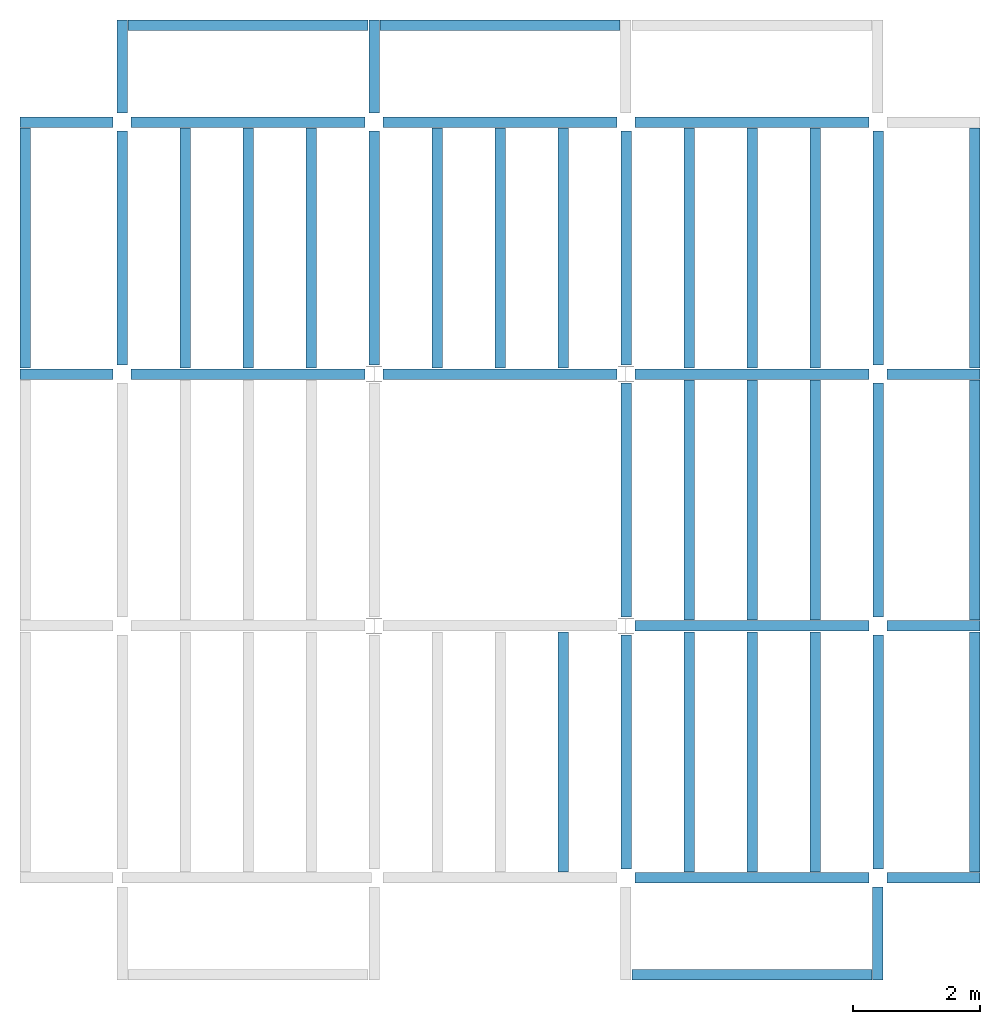
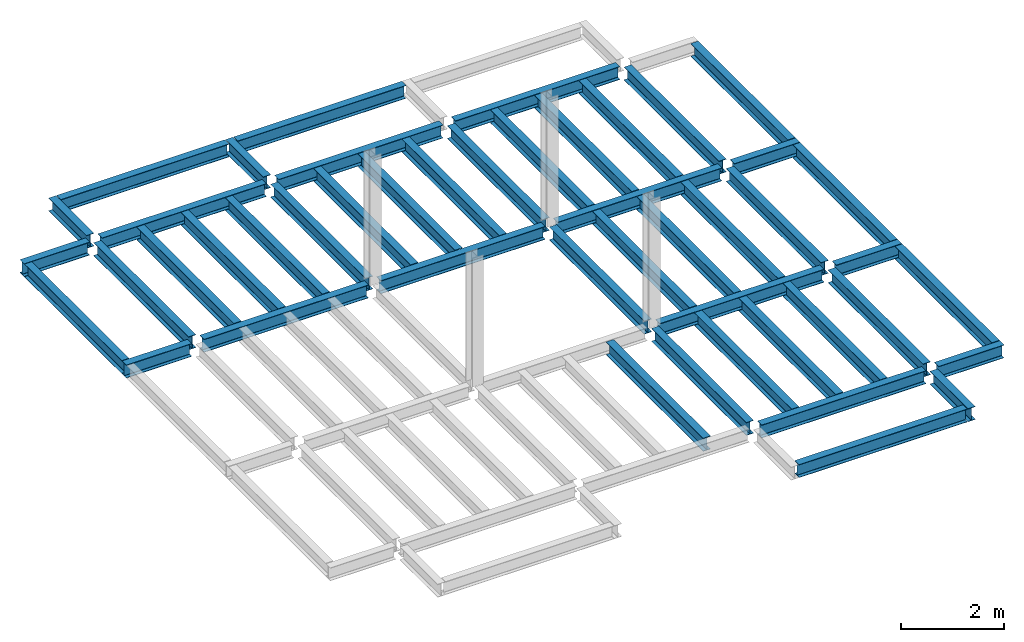
# One storey, part 2 of 3: 47 beams, 6 elements without a shape of their own.
"""IFC4 building model written with IfcOpenShell, lengths in feet."""

from ifc_helpers import new_model, entity, si_unit, converted_unit, derived_unit, direction, frame, origin, place, context, subcontext, project, spatial, line, arc, indexed_curve, outline, extrude, source, transform, mapped, material, type_object, type_shapes, element, aggregate, save


model = new_model("IFC4")

# Units and contexts
model_context = context("Model", 3, precision=0.0001, world=origin(), true_north=direction((6.123233995736766e-17, 1.0)))
plan_context = context("Plan", 3, precision=0.0001, world=origin(), true_north=direction((6.123233995736766e-17, 1.0)))
body_context = subcontext(model_context, "Body", "Model", "MODEL_VIEW")
ifc_project = project(units=[converted_unit("LENGTHUNIT", "FOOT", entity("IfcLengthMeasure", 0.3048), si_unit("LENGTHUNIT", "METRE"), dimensions=[1, 0, 0, 0, 0, 0, 0]), converted_unit("AREAUNIT", "SQUARE FOOT", entity("IfcAreaMeasure", 0.09290304), si_unit("AREAUNIT", "SQUARE_METRE"), dimensions=[2, 0, 0, 0, 0, 0, 0]), converted_unit("PLANEANGLEUNIT", "DEGREE", entity("IfcPlaneAngleMeasure", 0.017453292519943278), si_unit("PLANEANGLEUNIT", "RADIAN"), dimensions=[0, 0, 0, 0, 0, 0, 0]), converted_unit("VOLUMEUNIT", "CUBIC FOOT", entity("IfcVolumeMeasure", 0.028316846592000004), si_unit("VOLUMEUNIT", "CUBIC_METRE"), dimensions=[3, 0, 0, 0, 0, 0, 0]), si_unit("PRESSUREUNIT", "PASCAL"), derived_unit("MASSDENSITYUNIT", [(si_unit("MASSUNIT", "GRAM", prefix="KILO"), 1), (si_unit("LENGTHUNIT", "METRE"), -3)]), derived_unit("VAPORPERMEABILITYUNIT", [(si_unit("LENGTHUNIT", "METRE"), -1), (si_unit("TIMEUNIT", "SECOND"), 1)]), derived_unit("USERDEFINED", [(si_unit("MASSUNIT", "GRAM", prefix="KILO"), 1), (si_unit("LENGTHUNIT", "METRE"), 3), (si_unit("TIMEUNIT", "SECOND"), -3), (si_unit("ELECTRICCURRENTUNIT", "AMPERE"), -2)]), derived_unit("MODULUSOFELASTICITYUNIT", [(si_unit("MASSUNIT", "GRAM", prefix="KILO"), 1), (si_unit("LENGTHUNIT", "METRE"), -1), (si_unit("TIMEUNIT", "SECOND"), -2)]), derived_unit("THERMALEXPANSIONCOEFFICIENTUNIT", [(si_unit("THERMODYNAMICTEMPERATUREUNIT", "KELVIN"), -1)]), derived_unit("SPECIFICHEATCAPACITYUNIT", [(si_unit("TIMEUNIT", "SECOND"), -2), (si_unit("THERMODYNAMICTEMPERATUREUNIT", "KELVIN"), -1), (si_unit("LENGTHUNIT", "METRE"), 2)]), derived_unit("THERMALCONDUCTANCEUNIT", [(si_unit("MASSUNIT", "GRAM", prefix="KILO"), 1), (si_unit("TIMEUNIT", "SECOND"), -3), (si_unit("THERMODYNAMICTEMPERATUREUNIT", "KELVIN"), -1), (si_unit("LENGTHUNIT", "METRE"), 1)])], contexts=[model_context, plan_context])

# Site, building, storey
site_placement = place(None, origin())
site = spatial("IfcSite", under=ifc_project, at=site_placement, CompositionType="ELEMENT")
building_placement = place(site_placement, origin())
building = spatial("IfcBuilding", under=site, at=building_placement, CompositionType="ELEMENT")
storey_placement = place(building_placement, frame((0.0, 0.0, 129.875)))
storey = spatial("IfcBuildingStorey", under=building, at=storey_placement, Name="STR 14", CompositionType="ELEMENT", Elevation=129.875)

# Beams
ifc_material = material(Name="Steel ASTM A992", Category="Metal")
beam_type_1 = type_object("IfcBeamType", Name="W12X26", PredefinedType="JOIST", material=ifc_material)
shared_shape_1 = source(origin(), body_context, "Body", "SweptSolid", [
    extrude(outline(indexed_curve([(-0.27041666666666714, -0.47666666666666574), (-0.27041666666666714, -0.5083333333333351), (0.2704166666666669, -0.5083333333333351), (0.2704166666666669, -0.47666666666666574), (0.03458333333333309, -0.47666666666666574), (0.016905663803669493, -0.46934433619632937), (0.009583333333333202, -0.4516666666666659), (0.0095833333333332, 0.45166666666666705), (0.01690566380366948, 0.4693443361963307), (0.03458333333333325, 0.4766666666666671), (0.2704166666666669, 0.4766666666666671), (0.2704166666666669, 0.5083333333333312), (-0.2704166666666655, 0.5083333333333312), (-0.2704166666666655, 0.4766666666666671), (-0.034583333333333514, 0.47666666666666707), (-0.016905663803669865, 0.46934433619633054), (-0.009583333333333737, 0.45166666666666694), (-0.009583333333333735, -0.4516666666666658), (-0.01690566380367013, -0.4693443361963295), (-0.03458333333333368, -0.47666666666666574)], segments=[line(1, 2, 3, 4, 5), arc(5, 6, 7), line(7, 8), arc(8, 9, 10), line(10, 11, 12, 13, 14, 15), arc(15, 16, 17), line(17, 18), arc(18, 19, 20), line(20, 1)], self_intersect=False)), frame((-6.103346456692914, 0.0, 0.0), z_axis=(-1.0, 0.0, 0.0), x_axis=(0.0, -1.0, 0.0)), (0.0, 0.0, -1.0), 12.083333333333323),
])
type_shapes(beam_type_1, [shared_shape_1])
for number, where, z_axis, x_axis, name in (
    (1, (39.00958333333343, 6.56167979002612, -0.5083333333333258), (0.0, 0.0, 1.0), (0.0, 1.0, 0.0), "W12X26"),
    (2, (26.00958333333343, 6.561679790026162, -0.5083333333333258), (0.0, 0.0, 1.0), (0.0, 1.0, 0.0), "W12X26"),
):
    element("IfcBeam", number, at=place(storey_placement, frame(where, z_axis=z_axis, x_axis=x_axis)), inside=storey, type_object=beam_type_1, material=ifc_material, Name=name, ObjectType="W Shapes:W12X26", PredefinedType="JOIST", context=body_context, shape_type="MappedRepresentation", body=[
        mapped(shared_shape_1, transform((0.0, 0.0, 0.0), scale=1.0)),
    ])
beam_type_2 = type_object("IfcBeamType", Name="W12X26", PredefinedType="JOIST", material=ifc_material)
shared_shape_2 = source(origin(), body_context, "Body", "SweptSolid", [
    extrude(outline(indexed_curve([(-0.27041666666666714, -0.47666666666666574), (-0.27041666666666714, -0.5083333333333351), (0.2704166666666669, -0.5083333333333351), (0.2704166666666669, -0.47666666666666574), (0.03458333333333309, -0.47666666666666574), (0.016905663803669493, -0.46934433619632937), (0.009583333333333202, -0.4516666666666659), (0.0095833333333332, 0.45166666666666705), (0.01690566380366948, 0.4693443361963307), (0.03458333333333325, 0.4766666666666671), (0.2704166666666669, 0.4766666666666671), (0.2704166666666669, 0.5083333333333312), (-0.2704166666666655, 0.5083333333333312), (-0.2704166666666655, 0.4766666666666671), (-0.034583333333333514, 0.47666666666666707), (-0.016905663803669865, 0.46934433619633054), (-0.009583333333333737, 0.45166666666666694), (-0.009583333333333735, -0.4516666666666658), (-0.01690566380367013, -0.4693443361963295), (-0.03458333333333368, -0.47666666666666574)], segments=[line(1, 2, 3, 4, 5), arc(5, 6, 7), line(7, 8), arc(8, 9, 10), line(10, 11, 12, 13, 14, 15), arc(15, 16, 17), line(17, 18), arc(18, 19, 20), line(20, 1)], self_intersect=False)), frame((-6.226706036745409, 0.0, 0.0), z_axis=(-1.0, 0.0, 0.0), x_axis=(0.0, -1.0, 0.0)), (0.0, 0.0, -1.0), 12.08333333333333),
])
type_shapes(beam_type_2, [shared_shape_2])
for number, where, z_axis, x_axis, name in (
    (3, (39.009583333333445, 19.685039370078613, -0.5083333333333258), (0.0, 0.0, 1.0), (0.0, 1.0, 0.0), "W12X26"),
    (4, (26.009583333333453, 19.685039370078655, -0.5083333333333258), (0.0, 0.0, 1.0), (0.0, 1.0, 0.0), "W12X26"),
):
    element("IfcBeam", number, at=place(storey_placement, frame(where, z_axis=z_axis, x_axis=x_axis)), inside=storey, type_object=beam_type_2, material=ifc_material, Name=name, ObjectType="W Shapes:W12X26", PredefinedType="JOIST", context=body_context, shape_type="MappedRepresentation", body=[
        mapped(shared_shape_2, transform((0.0, 0.0, 0.0), scale=1.0)),
    ])

# Assembly, beams
assembly_1_placement = place(storey_placement, origin())
assembly_1 = element("IfcElementAssembly", 5, at=assembly_1_placement, inside=storey, Name="Structural Framing System", ObjectType="Structural Beam System:Structural Framing System", AssemblyPlace="NOTDEFINED", PredefinedType="BEAM_GRID")
beam_type_3 = type_object("IfcBeamType", Name="W12X26", PredefinedType="JOIST", material=ifc_material)
shared_shape_3 = source(origin(), body_context, "Body", "SweptSolid", [
    extrude(outline(indexed_curve([(-0.27041666666666714, -0.47666666666666574), (-0.27041666666666714, -0.5083333333333351), (0.2704166666666669, -0.5083333333333351), (0.2704166666666669, -0.47666666666666574), (0.03458333333333309, -0.47666666666666574), (0.016905663803669493, -0.46934433619632937), (0.009583333333333202, -0.4516666666666659), (0.0095833333333332, 0.45166666666666705), (0.01690566380366948, 0.4693443361963307), (0.03458333333333325, 0.4766666666666671), (0.2704166666666669, 0.4766666666666671), (0.2704166666666669, 0.5083333333333312), (-0.2704166666666655, 0.5083333333333312), (-0.2704166666666655, 0.4766666666666671), (-0.034583333333333514, 0.47666666666666707), (-0.016905663803669865, 0.46934433619633054), (-0.009583333333333737, 0.45166666666666694), (-0.009583333333333735, -0.4516666666666658), (-0.01690566380367013, -0.4693443361963295), (-0.03458333333333368, -0.47666666666666574)], segments=[line(1, 2, 3, 4, 5), arc(5, 6, 7), line(7, 8), arc(8, 9, 10), line(10, 11, 12, 13, 14, 15), arc(15, 16, 17), line(17, 18), arc(18, 19, 20), line(20, 1)], self_intersect=False)), frame((-6.187916666666566, 0.0, 0.0), z_axis=(-1.0, 0.0, 0.0), x_axis=(0.0, -1.0, 0.0)), (0.0, 0.0, -1.0), 12.375833333333075),
])
type_shapes(beam_type_3, [shared_shape_3])
beam_1_placement = place(assembly_1_placement, frame((3.252395833333405, 32.49999999999969, -0.5083333333333258), z_axis=(0.0, 0.0, 1.0), x_axis=(0.0, 1.0, 0.0)))
beam_1 = element("IfcBeam", 6, at=beam_1_placement, type_object=beam_type_3, material=ifc_material, Name="W12X26", ObjectType="W Shapes:W12X26", PredefinedType="JOIST", context=body_context, shape_type="MappedRepresentation", body=[
    mapped(shared_shape_3, transform((0.0, 0.0, 0.0), scale=1.0)),
])
beam_2_placement = place(assembly_1_placement, frame((6.504791666666758, 32.49999999999967, -0.5083333333333258), z_axis=(0.0, 0.0, 1.0), x_axis=(0.0, 1.0, 0.0)))
beam_2 = element("IfcBeam", 7, at=beam_2_placement, type_object=beam_type_3, material=ifc_material, Name="W12X26", ObjectType="W Shapes:W12X26", PredefinedType="JOIST", context=body_context, shape_type="MappedRepresentation", body=[
    mapped(shared_shape_3, transform((0.0, 0.0, 0.0), scale=1.0)),
])
beam_3_placement = place(assembly_1_placement, frame((9.757187500000112, 32.49999999999966, -0.5083333333333258), z_axis=(0.0, 0.0, 1.0), x_axis=(0.0, 1.0, 0.0)))
beam_3 = element("IfcBeam", 8, at=beam_3_placement, type_object=beam_type_3, material=ifc_material, Name="W12X26", ObjectType="W Shapes:W12X26", PredefinedType="JOIST", context=body_context, shape_type="MappedRepresentation", body=[
    mapped(shared_shape_3, transform((0.0, 0.0, 0.0), scale=1.0)),
])
aggregate(assembly_1, [beam_1, beam_2, beam_3])

# Assembly, beam
assembly_2_placement = place(storey_placement, origin())
assembly_2 = element("IfcElementAssembly", 9, at=assembly_2_placement, inside=storey, Name="Structural Framing System", ObjectType="Structural Beam System:Structural Framing System", AssemblyPlace="NOTDEFINED", PredefinedType="BEAM_GRID")
beam_4_placement = place(assembly_2_placement, frame((22.75718750000011, 6.4999999999998, -0.5083333333333258), z_axis=(0.0, 0.0, 1.0), x_axis=(0.0, 1.0, 0.0)))
beam_4 = element("IfcBeam", 10, at=beam_4_placement, type_object=beam_type_3, material=ifc_material, Name="W12X26", ObjectType="W Shapes:W12X26", PredefinedType="JOIST", context=body_context, shape_type="MappedRepresentation", body=[
    mapped(shared_shape_3, transform((0.0, 0.0, 0.0), scale=1.0)),
])
aggregate(assembly_2, [beam_4])

# Assembly, beams
assembly_3_placement = place(storey_placement, origin())
assembly_3 = element("IfcElementAssembly", 11, at=assembly_3_placement, inside=storey, Name="Structural Framing System", ObjectType="Structural Beam System:Structural Framing System", AssemblyPlace="NOTDEFINED", PredefinedType="BEAM_GRID")
beam_5_placement = place(assembly_3_placement, frame((16.259583333333467, 32.499999999999645, -0.5083333333333258), z_axis=(0.0, 0.0, 1.0), x_axis=(0.0, 1.0, 0.0)))
beam_5 = element("IfcBeam", 12, at=beam_5_placement, type_object=beam_type_3, material=ifc_material, Name="W12X26", ObjectType="W Shapes:W12X26", PredefinedType="JOIST", context=body_context, shape_type="MappedRepresentation", body=[
    mapped(shared_shape_3, transform((0.0, 0.0, 0.0), scale=1.0)),
])
beam_6_placement = place(assembly_3_placement, frame((19.50958333333347, 32.49999999999963, -0.5083333333333258), z_axis=(0.0, 0.0, 1.0), x_axis=(0.0, 1.0, 0.0)))
beam_6 = element("IfcBeam", 13, at=beam_6_placement, type_object=beam_type_3, material=ifc_material, Name="W12X26", ObjectType="W Shapes:W12X26", PredefinedType="JOIST", context=body_context, shape_type="MappedRepresentation", body=[
    mapped(shared_shape_3, transform((0.0, 0.0, 0.0), scale=1.0)),
])
beam_7_placement = place(assembly_3_placement, frame((22.75958333333347, 32.499999999999616, -0.5083333333333258), z_axis=(0.0, 0.0, 1.0), x_axis=(0.0, 1.0, 0.0)))
beam_7 = element("IfcBeam", 14, at=beam_7_placement, type_object=beam_type_3, material=ifc_material, Name="W12X26", ObjectType="W Shapes:W12X26", PredefinedType="JOIST", context=body_context, shape_type="MappedRepresentation", body=[
    mapped(shared_shape_3, transform((0.0, 0.0, 0.0), scale=1.0)),
])
aggregate(assembly_3, [beam_5, beam_6, beam_7])

assembly_4_placement = place(storey_placement, origin())
assembly_4 = element("IfcElementAssembly", 15, at=assembly_4_placement, inside=storey, Name="Structural Framing System", ObjectType="Structural Beam System:Structural Framing System", AssemblyPlace="NOTDEFINED", PredefinedType="BEAM_GRID")
beam_8_placement = place(assembly_4_placement, frame((29.25958333333343, 6.49999999999975, -0.5083333333333258), z_axis=(0.0, 0.0, 1.0), x_axis=(0.0, 1.0, 0.0)))
beam_8 = element("IfcBeam", 16, at=beam_8_placement, type_object=beam_type_3, material=ifc_material, Name="W12X26", ObjectType="W Shapes:W12X26", PredefinedType="JOIST", context=body_context, shape_type="MappedRepresentation", body=[
    mapped(shared_shape_3, transform((0.0, 0.0, 0.0), scale=1.0)),
])
beam_9_placement = place(assembly_4_placement, frame((32.509583333333424, 6.499999999999738, -0.5083333333333258), z_axis=(0.0, 0.0, 1.0), x_axis=(0.0, 1.0, 0.0)))
beam_9 = element("IfcBeam", 17, at=beam_9_placement, type_object=beam_type_3, material=ifc_material, Name="W12X26", ObjectType="W Shapes:W12X26", PredefinedType="JOIST", context=body_context, shape_type="MappedRepresentation", body=[
    mapped(shared_shape_3, transform((0.0, 0.0, 0.0), scale=1.0)),
])
beam_10_placement = place(assembly_4_placement, frame((35.759583333333424, 6.499999999999728, -0.5083333333333258), z_axis=(0.0, 0.0, 1.0), x_axis=(0.0, 1.0, 0.0)))
beam_10 = element("IfcBeam", 18, at=beam_10_placement, type_object=beam_type_3, material=ifc_material, Name="W12X26", ObjectType="W Shapes:W12X26", PredefinedType="JOIST", context=body_context, shape_type="MappedRepresentation", body=[
    mapped(shared_shape_3, transform((0.0, 0.0, 0.0), scale=1.0)),
])
aggregate(assembly_4, [beam_8, beam_9, beam_10])

assembly_5_placement = place(storey_placement, origin())
assembly_5 = element("IfcElementAssembly", 19, at=assembly_5_placement, inside=storey, Name="Structural Framing System", ObjectType="Structural Beam System:Structural Framing System", AssemblyPlace="NOTDEFINED", PredefinedType="BEAM_GRID")
beam_11_placement = place(assembly_5_placement, frame((29.259583333333453, 19.499999999999595, -0.5083333333333258), z_axis=(0.0, 0.0, 1.0), x_axis=(0.0, 1.0, 0.0)))
beam_11 = element("IfcBeam", 20, at=beam_11_placement, type_object=beam_type_3, material=ifc_material, Name="W12X26", ObjectType="W Shapes:W12X26", PredefinedType="JOIST", context=body_context, shape_type="MappedRepresentation", body=[
    mapped(shared_shape_3, transform((0.0, 0.0, 0.0), scale=1.0)),
])
beam_12_placement = place(assembly_5_placement, frame((32.50958333333345, 19.499999999999588, -0.5083333333333258), z_axis=(0.0, 0.0, 1.0), x_axis=(0.0, 1.0, 0.0)))
beam_12 = element("IfcBeam", 21, at=beam_12_placement, type_object=beam_type_3, material=ifc_material, Name="W12X26", ObjectType="W Shapes:W12X26", PredefinedType="JOIST", context=body_context, shape_type="MappedRepresentation", body=[
    mapped(shared_shape_3, transform((0.0, 0.0, 0.0), scale=1.0)),
])
beam_13_placement = place(assembly_5_placement, frame((35.75958333333345, 19.499999999999574, -0.5083333333333258), z_axis=(0.0, 0.0, 1.0), x_axis=(0.0, 1.0, 0.0)))
beam_13 = element("IfcBeam", 22, at=beam_13_placement, type_object=beam_type_3, material=ifc_material, Name="W12X26", ObjectType="W Shapes:W12X26", PredefinedType="JOIST", context=body_context, shape_type="MappedRepresentation", body=[
    mapped(shared_shape_3, transform((0.0, 0.0, 0.0), scale=1.0)),
])
aggregate(assembly_5, [beam_11, beam_12, beam_13])

assembly_6_placement = place(storey_placement, origin())
assembly_6 = element("IfcElementAssembly", 23, at=assembly_6_placement, inside=storey, Name="Structural Framing System", ObjectType="Structural Beam System:Structural Framing System", AssemblyPlace="NOTDEFINED", PredefinedType="BEAM_GRID")
beam_14_placement = place(assembly_6_placement, frame((29.259583333333474, 32.4999999999996, -0.5083333333333258), z_axis=(0.0, 0.0, 1.0), x_axis=(0.0, 1.0, 0.0)))
beam_14 = element("IfcBeam", 24, at=beam_14_placement, type_object=beam_type_3, material=ifc_material, Name="W12X26", ObjectType="W Shapes:W12X26", PredefinedType="JOIST", context=body_context, shape_type="MappedRepresentation", body=[
    mapped(shared_shape_3, transform((0.0, 0.0, 0.0), scale=1.0)),
])
beam_15_placement = place(assembly_6_placement, frame((32.50958333333347, 32.49999999999959, -0.5083333333333258), z_axis=(0.0, 0.0, 1.0), x_axis=(0.0, 1.0, 0.0)))
beam_15 = element("IfcBeam", 25, at=beam_15_placement, type_object=beam_type_3, material=ifc_material, Name="W12X26", ObjectType="W Shapes:W12X26", PredefinedType="JOIST", context=body_context, shape_type="MappedRepresentation", body=[
    mapped(shared_shape_3, transform((0.0, 0.0, 0.0), scale=1.0)),
])
beam_16_placement = place(assembly_6_placement, frame((35.75958333333347, 32.499999999999574, -0.5083333333333258), z_axis=(0.0, 0.0, 1.0), x_axis=(0.0, 1.0, 0.0)))
beam_16 = element("IfcBeam", 26, at=beam_16_placement, type_object=beam_type_3, material=ifc_material, Name="W12X26", ObjectType="W Shapes:W12X26", PredefinedType="JOIST", context=body_context, shape_type="MappedRepresentation", body=[
    mapped(shared_shape_3, transform((0.0, 0.0, 0.0), scale=1.0)),
])
aggregate(assembly_6, [beam_14, beam_15, beam_16])

# Beams
for number, where, z_axis, x_axis, name in (
    (27, (-5.0, 32.4999999999997, -0.5083333333333258), (0.0, 0.0, 1.0), (0.0, 1.0, 0.0), "W12X26"),
    (28, (44.0, 6.4999999999997, -0.5083333333333258), (0.0, 0.0, 1.0), (0.0, 1.0, 0.0), "W12X26"),
    (29, (44.0, 19.499999999999545, -0.5083333333333258), (0.0, 0.0, 1.0), (0.0, 1.0, 0.0), "W12X26"),
    (30, (44.0, 32.499999999999545, -0.5083333333333258), (0.0, 0.0, 1.0), (0.0, 1.0, 0.0), "W12X26"),
):
    element("IfcBeam", number, at=place(storey_placement, frame(where, z_axis=z_axis, x_axis=x_axis)), inside=storey, type_object=beam_type_3, material=ifc_material, Name=name, ObjectType="W Shapes:W12X26", PredefinedType="JOIST", context=body_context, shape_type="MappedRepresentation", body=[
        mapped(shared_shape_3, transform((0.0, 0.0, 0.0), scale=1.0)),
    ])
beam_17_placement = place(storey_placement, frame((6.5000000000001625, 44.0, -0.5083333333333258)))
element("IfcBeam", 31, at=beam_17_placement, inside=storey, type_object=beam_type_3, material=ifc_material, Name="W Shapes:W12X26", ObjectType="W Shapes:W12X26", PredefinedType="JOIST", context=body_context, shape_type="MappedRepresentation", body=[
    mapped(shared_shape_3, transform((0.0, 0.0, 0.0), scale=1.0)),
])
beam_type_4 = type_object("IfcBeamType", Name="W12X26", PredefinedType="JOIST", material=ifc_material)
shared_shape_4 = source(origin(), body_context, "Body", "SweptSolid", [
    extrude(outline(indexed_curve([(-0.27041666666666714, -0.47666666666666574), (-0.27041666666666714, -0.5083333333333351), (0.2704166666666669, -0.5083333333333351), (0.2704166666666669, -0.47666666666666574), (0.03458333333333309, -0.47666666666666574), (0.016905663803669493, -0.46934433619632937), (0.009583333333333202, -0.4516666666666659), (0.0095833333333332, 0.45166666666666705), (0.01690566380366948, 0.4693443361963307), (0.03458333333333325, 0.4766666666666671), (0.2704166666666669, 0.4766666666666671), (0.2704166666666669, 0.5083333333333312), (-0.2704166666666655, 0.5083333333333312), (-0.2704166666666655, 0.4766666666666671), (-0.034583333333333514, 0.47666666666666707), (-0.016905663803669865, 0.46934433619633054), (-0.009583333333333737, 0.45166666666666694), (-0.009583333333333735, -0.4516666666666658), (-0.01690566380367013, -0.4693443361963295), (-0.03458333333333368, -0.47666666666666574)], segments=[line(1, 2, 3, 4, 5), arc(5, 6, 7), line(7, 8), arc(8, 9, 10), line(10, 11, 12, 13, 14, 15), arc(15, 16, 17), line(17, 18), arc(18, 19, 20), line(20, 1)], self_intersect=False)), frame((-6.165026246719308, 0.0, 0.0), z_axis=(-1.0, 0.0, 0.0), x_axis=(0.0, -1.0, 0.0)), (0.0, 0.0, -1.0), 12.08333333333334),
])
type_shapes(beam_type_4, [shared_shape_4])
for number, where, z_axis, x_axis, name in (
    (32, (39.00958333333347, 32.62335958005221, -0.5083333333333258), (0.0, 0.0, 1.0), (0.0, 1.0, 0.0), "W12X26"),
    (33, (26.009583333333474, 32.62335958005225, -0.5083333333333258), (0.0, 0.0, 1.0), (0.0, 1.0, 0.0), "W12X26"),
    (34, (13.009583333333467, 32.623359580052295, -0.5083333333333258), (0.0, 0.0, 1.0), (0.0, 1.0, 0.0), "W12X26"),
    (35, (0.0, 32.62335958005234, -0.5083333333333258), (0.0, 0.0, 1.0), (0.0, 1.0, 0.0), "W12X26"),
):
    element("IfcBeam", number, at=place(storey_placement, frame(where, z_axis=z_axis, x_axis=x_axis)), inside=storey, type_object=beam_type_4, material=ifc_material, Name=name, ObjectType="W Shapes:W12X26", PredefinedType="JOIST", context=body_context, shape_type="MappedRepresentation", body=[
        mapped(shared_shape_4, transform((0.0, 0.0, 0.0), scale=1.0)),
    ])
beam_type_5 = type_object("IfcBeamType", Name="W12X26", PredefinedType="JOIST", material=ifc_material)
shared_shape_5 = source(origin(), body_context, "Body", "SweptSolid", [
    extrude(outline(indexed_curve([(-0.27041666666666714, -0.47666666666666574), (-0.27041666666666714, -0.5083333333333351), (0.2704166666666669, -0.5083333333333351), (0.2704166666666669, -0.47666666666666574), (0.03458333333333309, -0.47666666666666574), (0.016905663803669493, -0.46934433619632937), (0.009583333333333202, -0.4516666666666659), (0.0095833333333332, 0.45166666666666705), (0.01690566380366948, 0.4693443361963307), (0.03458333333333325, 0.4766666666666671), (0.2704166666666669, 0.4766666666666671), (0.2704166666666669, 0.5083333333333312), (-0.2704166666666655, 0.5083333333333312), (-0.2704166666666655, 0.4766666666666671), (-0.034583333333333514, 0.47666666666666707), (-0.016905663803669865, 0.46934433619633054), (-0.009583333333333737, 0.45166666666666694), (-0.009583333333333735, -0.4516666666666658), (-0.01690566380367013, -0.4693443361963295), (-0.03458333333333368, -0.47666666666666574)], segments=[line(1, 2, 3, 4, 5), arc(5, 6, 7), line(7, 8), arc(8, 9, 10), line(10, 11, 12, 13, 14, 15), arc(15, 16, 17), line(17, 18), arc(18, 19, 20), line(20, 1)], self_intersect=False)), frame((-6.0464583333332875, 0.0, 0.0), z_axis=(-1.0, 0.0, 0.0), x_axis=(0.0, -1.0, 0.0)), (0.0, 0.0, -1.0), 12.083333333333329),
])
type_shapes(beam_type_5, [shared_shape_5])
for number, where, name in (
    (36, (6.504791666666769, 39.0, -0.5083333333333258), "W12X26"),
    (37, (6.5047916666667485, 26.0, -0.5083333333333258), "W12X26"),
):
    element("IfcBeam", number, at=place(storey_placement, frame(where)), inside=storey, type_object=beam_type_5, material=ifc_material, Name=name, ObjectType="W Shapes:W12X26", PredefinedType="JOIST", context=body_context, shape_type="MappedRepresentation", body=[
        mapped(shared_shape_5, transform((0.0, 0.0, 0.0), scale=1.0)),
    ])
beam_type_6 = type_object("IfcBeamType", Name="W12X26", PredefinedType="JOIST", material=ifc_material)
shared_shape_6 = source(origin(), body_context, "Body", "SweptSolid", [
    extrude(outline(indexed_curve([(-0.27041666666666714, -0.47666666666666574), (-0.27041666666666714, -0.5083333333333351), (0.2704166666666669, -0.5083333333333351), (0.2704166666666669, -0.47666666666666574), (0.03458333333333309, -0.47666666666666574), (0.016905663803669493, -0.46934433619632937), (0.009583333333333202, -0.4516666666666659), (0.0095833333333332, 0.45166666666666705), (0.01690566380366948, 0.4693443361963307), (0.03458333333333325, 0.4766666666666671), (0.2704166666666669, 0.4766666666666671), (0.2704166666666669, 0.5083333333333312), (-0.2704166666666655, 0.5083333333333312), (-0.2704166666666655, 0.4766666666666671), (-0.034583333333333514, 0.47666666666666707), (-0.016905663803669865, 0.46934433619633054), (-0.009583333333333737, 0.45166666666666694), (-0.009583333333333735, -0.4516666666666658), (-0.01690566380367013, -0.4693443361963295), (-0.03458333333333368, -0.47666666666666574)], segments=[line(1, 2, 3, 4, 5), arc(5, 6, 7), line(7, 8), arc(8, 9, 10), line(10, 11, 12, 13, 14, 15), arc(15, 16, 17), line(17, 18), arc(18, 19, 20), line(20, 1)], self_intersect=False)), frame((-6.051249999999997, 0.0, 0.0), z_axis=(-1.0, 0.0, 0.0), x_axis=(0.0, -1.0, 0.0)), (0.0, 0.0, -1.0), 12.083333333333329),
])
type_shapes(beam_type_6, [shared_shape_6])
for number, where, name in (
    (38, (19.50958333333348, 39.0, -0.5083333333333258), "W12X26"),
    (39, (32.50958333333348, 39.0, -0.5083333333333258), "W12X26"),
    (40, (19.50958333333346, 26.0, -0.5083333333333258), "W12X26"),
    (41, (32.50958333333346, 26.0, -0.5083333333333258), "W12X26"),
    (42, (32.50958333333344, 13.0, -0.5083333333333258), "W12X26"),
    (43, (32.50958333333342, 0.0, -0.5083333333333258), "W12X26"),
):
    element("IfcBeam", number, at=place(storey_placement, frame(where)), inside=storey, type_object=beam_type_6, material=ifc_material, Name=name, ObjectType="W Shapes:W12X26", PredefinedType="JOIST", context=body_context, shape_type="MappedRepresentation", body=[
        mapped(shared_shape_6, transform((0.0, 0.0, 0.0), scale=1.0)),
    ])
beam_type_7 = type_object("IfcBeamType", Name="W12X26", PredefinedType="JOIST", material=ifc_material)
shared_shape_7 = source(origin(), body_context, "Body", "SweptSolid", [
    extrude(outline(indexed_curve([(0.47666666666666574, -0.2704166666666672), (0.5083333333333351, -0.2704166666666672), (0.5083333333333351, 0.27041666666666686), (0.47666666666666574, 0.27041666666666686), (0.47666666666666574, 0.03458333333333307), (0.46934433619632937, 0.016905663803669473), (0.4516666666666659, 0.00958333333333318), (-0.45166666666666705, 0.00958333333333318), (-0.4693443361963307, 0.01690566380366946), (-0.4766666666666671, 0.03458333333333323), (-0.4766666666666671, 0.27041666666666686), (-0.5083333333333312, 0.27041666666666686), (-0.5083333333333312, -0.27041666666666553), (-0.4766666666666671, -0.27041666666666553), (-0.47666666666666707, -0.034583333333333535), (-0.46934433619633054, -0.016905663803669885), (-0.45166666666666694, -0.00958333333333376), (0.4516666666666658, -0.009583333333333756), (0.4693443361963295, -0.01690566380367015), (0.47666666666666574, -0.0345833333333337)], segments=[line(1, 2, 3, 4, 5), arc(5, 6, 7), line(7, 8), arc(8, 9, 10), line(10, 11, 12, 13, 14, 15), arc(15, 16, 17), line(17, 18), arc(18, 19, 20), line(20, 1)], self_intersect=False)), frame((-2.0416666666666208, 0.0, 0.0), z_axis=(1.0, 0.0, 0.0), x_axis=(0.0, 0.0, -1.0)), (0.0, 0.0, 1.0), 4.812083333333336),
])
type_shapes(beam_type_7, [shared_shape_7])
for number, where, z_axis, x_axis, name in (
    (44, (-2.4999999999998104, 39.0, -0.5083333333333258), (0.0, 0.0, 1.0), (-1.0, 0.0, 0.0), "W12X26"),
    (45, (39.0, -2.50000000000058, -0.5083333333333258), (0.0, 0.0, 1.0), (0.0, -1.0, 0.0), "W12X26"),
    (46, (-2.4999999999998317, 26.0, -0.5083333333333258), (0.0, 0.0, 1.0), (-1.0, 0.0, 0.0), "W12X26"),
):
    element("IfcBeam", number, at=place(storey_placement, frame(where, z_axis=z_axis, x_axis=x_axis)), inside=storey, type_object=beam_type_7, material=ifc_material, Name=name, ObjectType="W Shapes:W12X26", PredefinedType="JOIST", context=body_context, shape_type="MappedRepresentation", body=[
        mapped(shared_shape_7, transform((0.0, 0.0, 0.0), scale=1.0)),
    ])
beam_type_8 = type_object("IfcBeamType", Name="W12X26", PredefinedType="JOIST", material=ifc_material)
shared_shape_8 = source(origin(), body_context, "Body", "SweptSolid", [
    extrude(outline(indexed_curve([(0.47666666666666574, -0.2704166666666672), (0.5083333333333351, -0.2704166666666672), (0.5083333333333351, 0.27041666666666686), (0.47666666666666574, 0.27041666666666686), (0.47666666666666574, 0.03458333333333307), (0.46934433619632937, 0.016905663803669473), (0.4516666666666659, 0.00958333333333318), (-0.45166666666666705, 0.00958333333333318), (-0.4693443361963307, 0.01690566380366946), (-0.4766666666666671, 0.03458333333333323), (-0.4766666666666671, 0.27041666666666686), (-0.5083333333333312, 0.27041666666666686), (-0.5083333333333312, -0.27041666666666553), (-0.4766666666666671, -0.27041666666666553), (-0.47666666666666707, -0.034583333333333535), (-0.46934433619633054, -0.016905663803669885), (-0.45166666666666694, -0.00958333333333376), (0.4516666666666658, -0.009583333333333756), (0.4693443361963295, -0.01690566380367015), (0.47666666666666574, -0.0345833333333337)], segments=[line(1, 2, 3, 4, 5), arc(5, 6, 7), line(7, 8), arc(8, 9, 10), line(10, 11, 12, 13, 14, 15), arc(15, 16, 17), line(17, 18), arc(18, 19, 20), line(20, 1)], self_intersect=False)), frame((-2.77041666666672, 0.0, 0.0), z_axis=(1.0, 0.0, 0.0), x_axis=(0.0, 0.0, -1.0)), (0.0, 0.0, 1.0), 4.812083333333389),
])
type_shapes(beam_type_8, [shared_shape_8])
for number, where, z_axis, x_axis, name in (
    (47, (41.50000000000013, 26.0, -0.5083333333333258), (0.0, 0.0, 1.0), (-1.0, 0.0, 0.0), "W12X26"),
    (48, (41.50000000000011, 13.0, -0.5083333333333258), (0.0, 0.0, 1.0), (-1.0, 0.0, 0.0), "W12X26"),
    (49, (41.500000000000085, 0.0, -0.5083333333333258), (0.0, 0.0, 1.0), (-1.0, 0.0, 0.0), "W12X26"),
    (50, (13.0, 41.49999999999965, -0.5083333333333258), (0.0, 0.0, 1.0), (0.0, -1.0, 0.0), "W12X26"),
    (51, (0.0, 41.499999999999694, -0.5083333333333258), (0.0, 0.0, 1.0), (0.0, -1.0, 0.0), "W12X26"),
):
    element("IfcBeam", number, at=place(storey_placement, frame(where, z_axis=z_axis, x_axis=x_axis)), inside=storey, type_object=beam_type_8, material=ifc_material, Name=name, ObjectType="W Shapes:W12X26", PredefinedType="JOIST", context=body_context, shape_type="MappedRepresentation", body=[
        mapped(shared_shape_8, transform((0.0, 0.0, 0.0), scale=1.0)),
    ])
beam_type_9 = type_object("IfcBeamType", Name="W12X26", PredefinedType="JOIST", material=ifc_material)
shared_shape_9 = source(origin(), body_context, "Body", "SweptSolid", [
    extrude(outline(indexed_curve([(0.47666666666666574, -0.2704166666666672), (0.5083333333333351, -0.2704166666666672), (0.5083333333333351, 0.27041666666666686), (0.47666666666666574, 0.27041666666666686), (0.47666666666666574, 0.03458333333333307), (0.46934433619632937, 0.016905663803669473), (0.4516666666666659, 0.00958333333333318), (-0.45166666666666705, 0.00958333333333318), (-0.4693443361963307, 0.01690566380366946), (-0.4766666666666671, 0.03458333333333323), (-0.4766666666666671, 0.27041666666666686), (-0.5083333333333312, 0.27041666666666686), (-0.5083333333333312, -0.27041666666666553), (-0.4766666666666671, -0.27041666666666553), (-0.47666666666666707, -0.034583333333333535), (-0.46934433619633054, -0.016905663803669885), (-0.45166666666666694, -0.00958333333333376), (0.4516666666666658, -0.009583333333333756), (0.4693443361963295, -0.01690566380367015), (0.47666666666666574, -0.0345833333333337)], segments=[line(1, 2, 3, 4, 5), arc(5, 6, 7), line(7, 8), arc(8, 9, 10), line(10, 11, 12, 13, 14, 15), arc(15, 16, 17), line(17, 18), arc(18, 19, 20), line(20, 1)], self_intersect=False)), frame((-6.187916666666685, 0.0, 0.0), z_axis=(1.0, 0.0, 0.0), x_axis=(0.0, 0.0, -1.0)), (0.0, 0.0, 1.0), 12.375833333333318),
])
type_shapes(beam_type_9, [shared_shape_9])
beam_18_placement = place(storey_placement, frame((19.500000000000142, 44.0, -0.5083333333333258), z_axis=(0.0, 0.0, 1.0), x_axis=(-1.0, 0.0, 0.0)))
element("IfcBeam", 52, at=beam_18_placement, inside=storey, type_object=beam_type_9, material=ifc_material, Name="W Shapes:W12X26", ObjectType="W Shapes:W12X26", PredefinedType="JOIST", context=body_context, shape_type="MappedRepresentation", body=[
    mapped(shared_shape_9, transform((0.0, 0.0, 0.0), scale=1.0)),
])
beam_19_placement = place(storey_placement, frame((32.50000000000002, -5.0, -0.5083333333333258)))
element("IfcBeam", 53, at=beam_19_placement, inside=storey, type_object=beam_type_9, material=ifc_material, Name="W Shapes:W12X26", ObjectType="W Shapes:W12X26", PredefinedType="JOIST", context=body_context, shape_type="MappedRepresentation", body=[
    mapped(shared_shape_9, transform((0.0, 0.0, 0.0), scale=1.0)),
])

save(model, "model.ifc")
